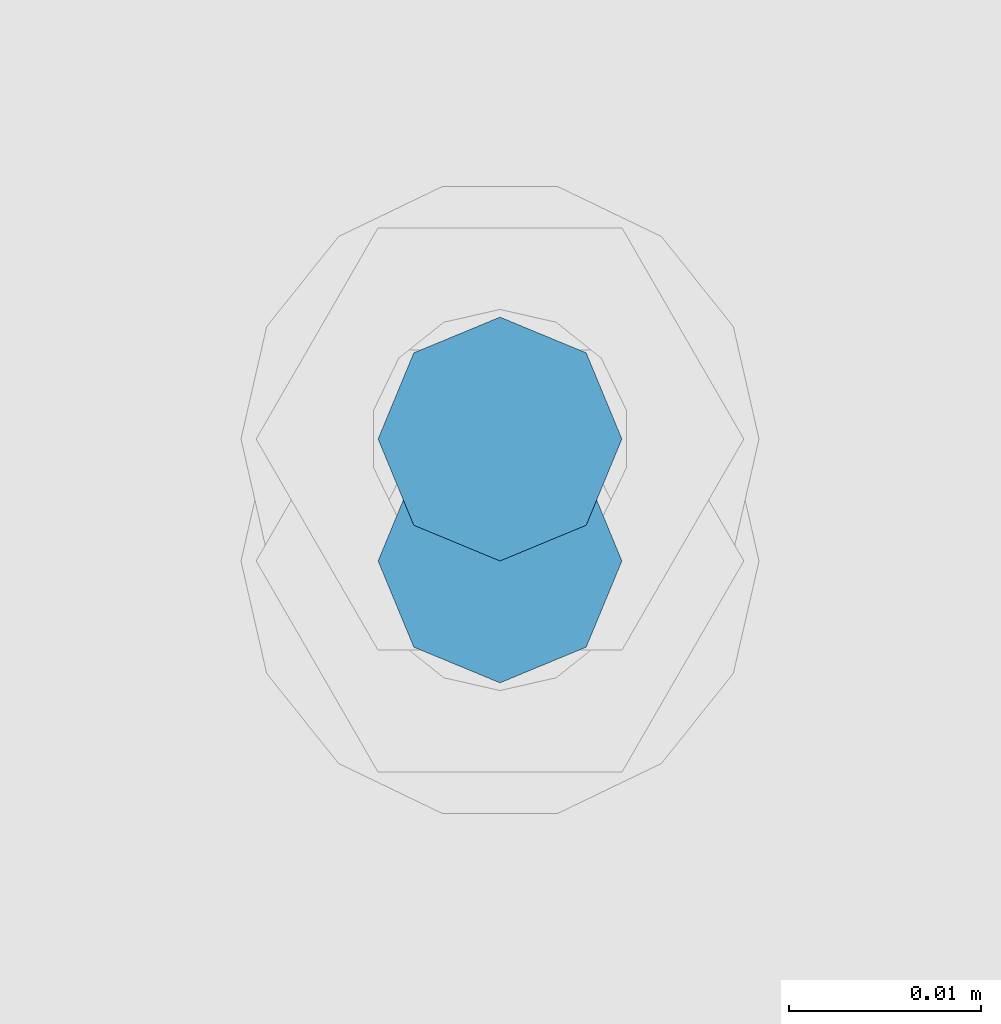
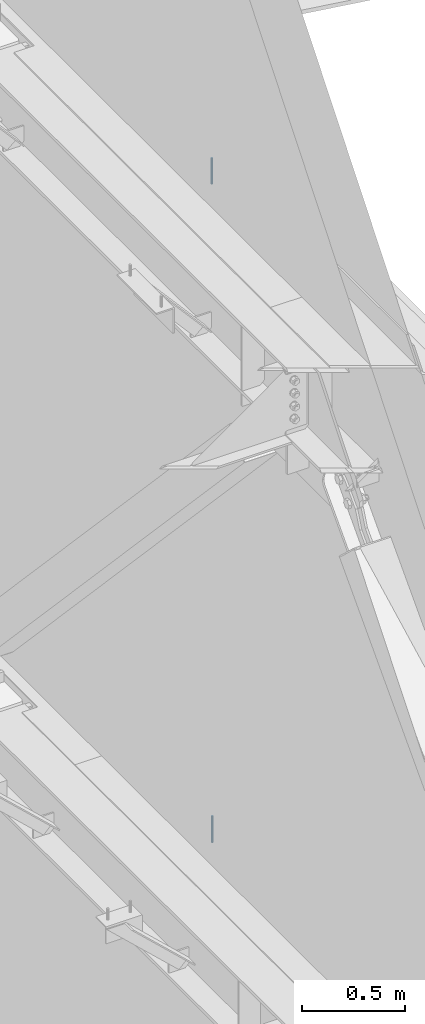
# One storey, part 551 of 1179: 2 columns, 2 elements without a shape of their own.
"""IFC2X3 building model written with IfcOpenShell, lengths in millimetres."""

from ifc_helpers import new_model, si_unit, frame, origin_with_axes, place, context, subcontext, project, spatial, faceted_brep, material, type_object, element, aggregate, save


model = new_model("IFC2X3")

# Units and contexts
model_context = context("Model", 3, precision=1e-05, world=origin_with_axes())
body_context = subcontext(model_context, "Body", "Model", "MODEL_VIEW")
ifc_project = project(units=[si_unit("LENGTHUNIT", "METRE", prefix="MILLI"), si_unit("AREAUNIT", "SQUARE_METRE"), si_unit("VOLUMEUNIT", "CUBIC_METRE"), si_unit("MASSUNIT", "GRAM", prefix="KILO"), si_unit("TIMEUNIT", "SECOND"), si_unit("PLANEANGLEUNIT", "RADIAN"), si_unit("SOLIDANGLEUNIT", "STERADIAN"), si_unit("THERMODYNAMICTEMPERATUREUNIT", "DEGREE_CELSIUS"), si_unit("LUMINOUSINTENSITYUNIT", "LUMEN")], contexts=[model_context])

# Site, building, storey
site_placement = place(None, origin_with_axes())
site = spatial("IfcSite", under=ifc_project, at=site_placement, CompositionType="ELEMENT")
building_placement = place(site_placement, origin_with_axes())
building = spatial("IfcBuilding", under=site, at=building_placement, Name="Undefined", CompositionType="ELEMENT")
storey_placement = place(building_placement, origin_with_axes())
storey = spatial("IfcBuildingStorey", under=building, at=storey_placement, Name="Undefined", CompositionType="ELEMENT", Elevation=0.0)

# Assembly, column
assembly_1_placement = place(storey_placement, origin_with_axes())
assembly_1 = element("IfcElementAssembly", 1, at=assembly_1_placement, inside=storey, Name="BEAM", AssemblyPlace="NOTDEFINED", PredefinedType="RIGID_FRAME")
ifc_material = material(Name="STEEL/A307")
column_type = type_object("IfcColumnType", PredefinedType="NOTDEFINED")
column_1_placement = place(assembly_1_placement, frame((24638.0000051215, 32251.6500001664, 8023.22499553788), z_axis=(0.0, 1.0, 0.0), x_axis=(0.0, 0.0, 1.0)))
column_1 = element("IfcColumn", 2, at=column_1_placement, type_object=column_type, material=ifc_material, Name="THREADED ROD", context=body_context, shape_type="Brep", body=[
    faceted_brep([(0.0, -6.34999999999854, 0.0), (0.0, -4.49012806053361, -4.49012806053452), (153.987504462122, -4.49012806053361, -4.49012806053361), (153.987504462122, -6.34999999999854, 0.0), (0.0, 0.0, -6.34999999999991), (153.987504462122, 0.0, -6.34999999999854), (0.0, 4.49012806053361, -4.49012806053452), (153.987504462122, 4.49012806053361, -4.49012806053361), (0.0, 6.34999999999854, 0.0), (153.987504462122, 6.34999999999854, 0.0), (0.0, 4.49012806053361, 4.49012806053452), (153.987504462122, 4.49012806053361, 4.49012806053361), (0.0, 0.0, 6.34999999999991), (153.987504462122, 0.0, 6.34999999999854), (0.0, -4.49012806053361, 4.49012806053452), (153.987504462122, -4.49012806053361, 4.49012806053361)], [[[0, 1, 2, 3]], [[1, 4, 5, 2]], [[4, 6, 7, 5]], [[6, 8, 9, 7]], [[8, 10, 11, 9]], [[10, 12, 13, 11]], [[12, 14, 15, 13]], [[14, 0, 3, 15]], [[5, 7, 9, 11, 13, 15, 3, 2]], [[14, 12, 10, 8, 6, 4, 1, 0]]]),
])
aggregate(assembly_1, [column_1])

assembly_2_placement = place(storey_placement, origin_with_axes())
assembly_2 = element("IfcElementAssembly", 3, at=assembly_2_placement, inside=storey, Name="BEAM", AssemblyPlace="NOTDEFINED", PredefinedType="RIGID_FRAME")
column_2_placement = place(assembly_2_placement, frame((24638.0, 32245.30025, 4108.45), z_axis=(0.0, 1.0, 0.0), x_axis=(0.0, 0.0, 1.0)))
column_2 = element("IfcColumn", 4, at=column_2_placement, type_object=column_type, material=ifc_material, Name="THREADED ROD", context=body_context, shape_type="Brep", body=[
    faceted_brep([(0.0, -6.34999999999854, 0.0), (0.0, -4.49012806053361, -4.49012806053452), (157.162499999999, -4.49012806053361, -4.49012806053361), (157.162499999999, -6.34999999999854, 0.0), (0.0, 0.0, -6.34999999999991), (157.162499999999, 0.0, -6.34999999999854), (0.0, 4.49012806053361, -4.49012806053452), (157.162499999999, 4.49012806053361, -4.49012806053361), (0.0, 6.34999999999854, 0.0), (157.162499999999, 6.34999999999854, 0.0), (0.0, 4.49012806053361, 4.49012806053452), (157.162499999999, 4.49012806053361, 4.49012806053361), (0.0, 0.0, 6.34999999999991), (157.162499999999, 0.0, 6.34999999999854), (0.0, -4.49012806053361, 4.49012806053452), (157.162499999999, -4.49012806053361, 4.49012806053361)], [[[0, 1, 2, 3]], [[1, 4, 5, 2]], [[4, 6, 7, 5]], [[6, 8, 9, 7]], [[8, 10, 11, 9]], [[10, 12, 13, 11]], [[12, 14, 15, 13]], [[14, 0, 3, 15]], [[5, 7, 9, 11, 13, 15, 3, 2]], [[14, 12, 10, 8, 6, 4, 1, 0]]]),
])
aggregate(assembly_2, [column_2])

save(model, "model.ifc")
